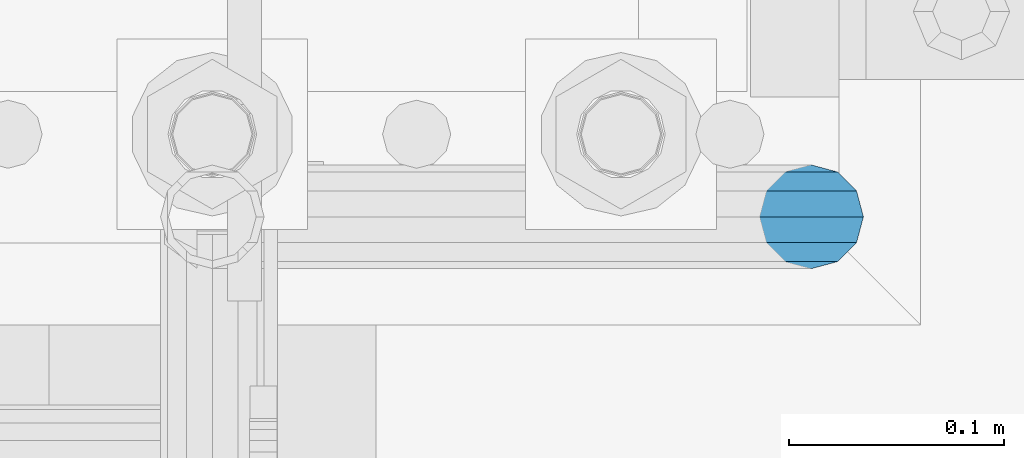
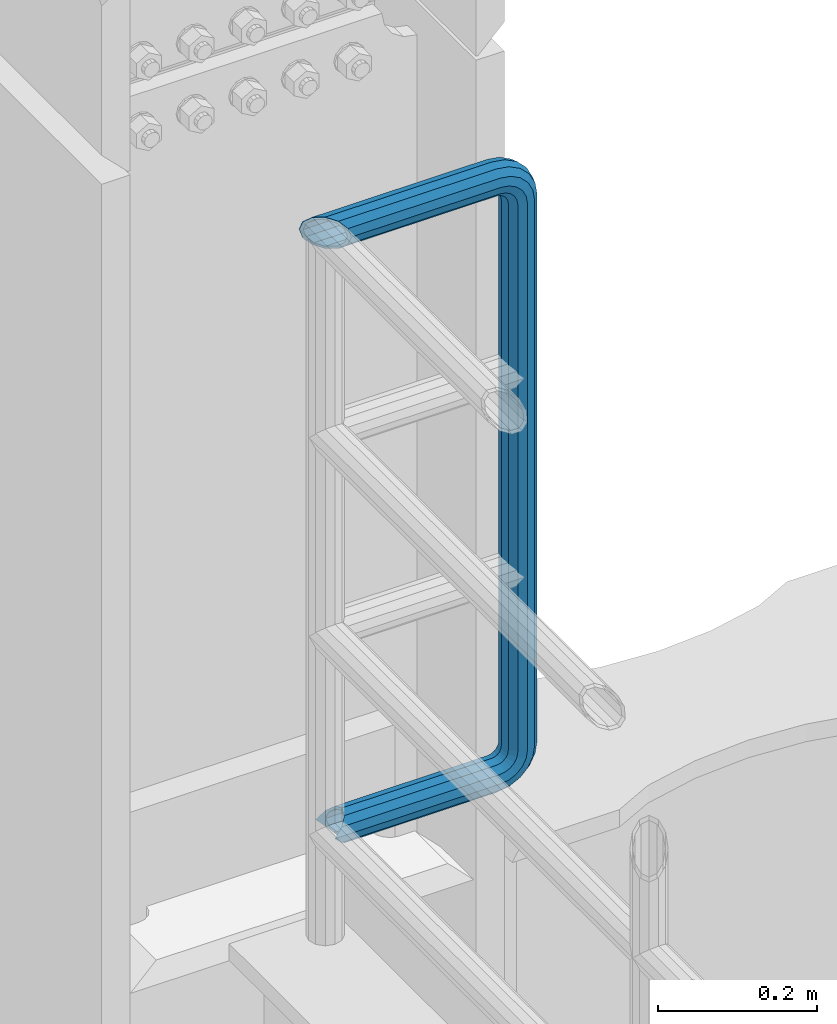
# One storey, part 1055 of 1876: 1 beam, 1 element without a shape of its own.
"""IFC2X3 building model written with IfcOpenShell, lengths in millimetres."""

from ifc_helpers import new_model, si_unit, frame, origin_with_axes, place, context, subcontext, project, spatial, faceted_brep, material, type_object, element, aggregate, save


model = new_model("IFC2X3")

# Units and contexts
model_context = context("Model", 3, precision=1e-05, world=origin_with_axes())
body_context = subcontext(model_context, "Body", "Model", "MODEL_VIEW")
ifc_project = project(units=[si_unit("LENGTHUNIT", "METRE", prefix="MILLI"), si_unit("AREAUNIT", "SQUARE_METRE"), si_unit("VOLUMEUNIT", "CUBIC_METRE"), si_unit("MASSUNIT", "GRAM", prefix="KILO"), si_unit("TIMEUNIT", "SECOND"), si_unit("PLANEANGLEUNIT", "RADIAN"), si_unit("SOLIDANGLEUNIT", "STERADIAN"), si_unit("THERMODYNAMICTEMPERATUREUNIT", "DEGREE_CELSIUS"), si_unit("LUMINOUSINTENSITYUNIT", "LUMEN")], contexts=[model_context])

# Site, building, storey
site_placement = place(None, origin_with_axes())
site = spatial("IfcSite", under=ifc_project, at=site_placement, CompositionType="ELEMENT")
building_placement = place(site_placement, origin_with_axes())
building = spatial("IfcBuilding", under=site, at=building_placement, Name="Undefined", CompositionType="ELEMENT")
storey_placement = place(building_placement, origin_with_axes())
storey = spatial("IfcBuildingStorey", under=building, at=storey_placement, Name="Undefined", CompositionType="ELEMENT", Elevation=0.0)

# Assembly, beam
assembly_placement = place(storey_placement, origin_with_axes())
assembly = element("IfcElementAssembly", 1, at=assembly_placement, inside=storey, Name="RAIL", AssemblyPlace="NOTDEFINED", PredefinedType="RIGID_FRAME")
ifc_material = material()
beam_type = type_object("IfcBeamType", Name="PIPE1-1/2SCH40", PredefinedType="NOTDEFINED")
beam_placement = place(assembly_placement, frame((-3.18323145620525e-12, 13499.7063, 14385.925), z_axis=(0.0, 0.0, 1.0), x_axis=(1.0, 0.0, 0.0)))
beam = element("IfcBeam", 2, at=beam_placement, type_object=beam_type, material=ifc_material, Name="RAIL", ObjectType="PIPE1-1/2SCH40", context=body_context, shape_type="Brep", body=[
    faceted_brep([(1.20714750983051e-12, 24.1299999999974, -914.399963378906), (12.0650000000014, 20.8971929933159, -926.464963378905), (12.0650000000014, 20.8971929933177, -902.334963378908), (12.0650000000014, -20.8971929933195, -902.334963378908), (12.0650000000014, -20.8971929933195, -926.464963378905), (1.52133659548828e-12, -24.130000000001, -914.399963378906), (20.8971929933199, -12.0650000000023, -893.502770385589), (20.8971929933199, -12.0650000000005, -898.533841947723), (15.2545715621378, -17.7076214311819, -904.176463378906), (12.5151929933181, -20.4470000000019, -914.399963378906), (15.2545715621376, -17.7076214311819, -924.623463378906), (20.8971929933199, -12.0650000000005, -930.26608481009), (20.8971929933199, -12.0650000000023, -935.297156372224), (24.1300000000014, -1.81898940354586e-12, -934.846963378906), (24.1300000000014, -1.81898940354586e-12, -938.529963378907), (21.3906214311813, -10.2235000000019, -932.107584810088), (21.3906214311823, 10.2234999999982, -932.107584810088), (20.8971929933199, 12.0650000000005, -930.266084810086), (20.8971929933199, 12.0649999999987, -935.297156372224), (15.2545715621413, 17.7076214311783, -924.623463378906), (12.5151929933216, 20.4469999999983, -914.399963378906), (15.2545715621411, 17.7076214311783, -904.176463378906), (20.8971929933199, 12.0650000000005, -898.533841947727), (20.8971929933199, 12.0649999999987, -893.502770385589), (21.3906214311822, 10.2234999999982, -896.692341947724), (24.1300000000014, 0.0, -893.952963378906), (24.1300000000014, 0.0, -890.269963378905), (21.3906214311814, -10.2235000000019, -896.692341947724), (241.299995422363, -20.8971929933177, 12.0649999999987), (241.299995422363, -24.1299999999992, 0.0), (253.073542436527, -24.1299999999992, -1.86474665447167), (256.801832473661, -20.8971929933177, 9.60975021462946), (241.299995422363, -12.0650000000005, 20.8971929933177), (259.531130206197, -12.0650000000005, 18.0096649141014), (241.299995422363, 0.0, 24.130000000001), (260.530122510796, 0.0, 21.084247083727), (241.299995422363, 12.0650000000005, 20.8971929933177), (259.531130206197, 12.0650000000005, 18.0096649141014), (241.299995422363, 20.8971929933177, 12.0649999999987), (256.801832473661, 20.8971929933177, 9.60975021462946), (241.299995422363, 24.1299999999992, 0.0), (253.073542436527, 24.1299999999992, -1.86474665447167), (241.299995422363, 20.8971929933177, -12.0649999999987), (249.345252399393, 20.8971929933177, -13.3392435235728), (241.299995422363, 12.0650000000005, -20.8971929933177), (246.615954666858, 12.0650000000005, -21.7391582230448), (241.299995422363, 0.0, -24.130000000001), (245.616962362259, 0.0, -24.8137403926739), (241.299995422363, -12.0650000000005, -20.8971929933177), (246.615954666858, -12.0650000000005, -21.7391582230448), (241.299995422363, -20.8971929933177, -12.0649999999987), (249.345252399393, -20.8971929933177, -13.3392435235728), (267.334993896485, 20.8971929933177, -38.0999984741211), (279.399993896485, 24.1299999999992, -38.0999984741211), (279.399993896484, 24.1299999999992, -876.299964904785), (267.334993896484, 20.8971929933177, -876.299964904785), (291.464993896486, 20.8971929933177, -38.0999984741211), (291.464993896484, 20.8971929933177, -876.299964904785), (300.297186889804, 12.0650000000005, -38.0999984741211), (300.297186889803, 12.0650000000005, -876.299964904785), (303.529993896486, 0.0, -38.0999984741211), (303.529993896484, 0.0, -876.299964904785), (300.297186889804, -12.0650000000005, -38.0999984741211), (300.297186889803, -12.0650000000005, -876.299964904785), (291.464993896486, -20.8971929933177, -38.0999984741211), (291.464993896484, -20.8971929933177, -876.299964904785), (279.399993896484, -24.1299999999992, -38.0999984741211), (279.399993896484, -24.1299999999992, -876.299964904785), (267.334993896485, -20.8971929933177, -38.0999984741211), (267.334993896484, -20.8971929933177, -876.299964904785), (258.502800903167, -12.0650000000005, -38.0999984741211), (258.502800903166, -12.0650000000005, -876.299964904785), (255.269993896485, 0.0, -38.0999984741211), (255.269993896484, 0.0, -876.299964904785), (258.502800903167, 12.0650000000005, -38.0999984741211), (258.502800903166, 12.0650000000005, -876.299964904785), (257.660835673438, 12.0650000000005, -881.615924149282), (254.586253503809, 0.0, -880.616931844681), (257.660835673438, -12.0650000000005, -881.615924149282), (266.06075037291, -20.8971929933177, -884.345221881817), (277.535247242011, -24.130000000001, -888.073511918952), (289.009744111112, -20.8971929933195, -891.801801956084), (297.409658810584, -12.0650000000005, -894.531099688622), (300.484240980214, 0.0, -895.53009199322), (297.409658810584, 12.0650000000005, -894.531099688622), (289.009744111112, 20.8971929933177, -891.801801956084), (277.535247242011, 24.1299999999992, -888.073511918952), (266.06075037291, 20.8971929933177, -884.345221881817), (241.299995422364, -1.81898940354586e-12, -938.529963378911), (241.299995422364, -12.0650000000005, -935.297156372228), (241.299995422364, -20.8971929933195, -926.464963378909), (241.299995422363, -24.130000000001, -914.399963378906), (241.299995422363, -20.8971929933195, -902.334963378908), (241.299995422363, -12.0650000000005, -893.502770385589), (241.299995422363, 0.0, -890.269963378909), (241.299995422364, 20.8971929933177, -926.464963378909), (241.299995422364, 12.0649999999987, -935.297156372228), (241.299995422364, 24.1299999999992, -914.39996337891), (241.299995422363, 20.8971929933177, -902.334963378908), (241.299995422363, 12.0649999999987, -893.502770385589), (260.530122510801, 0.0, -935.484210462637), (259.531130206202, 12.0649999999987, -932.409628293008), (259.531130206201, -12.0650000000005, -932.409628293008), (256.801832473666, -20.8971929933195, -924.009713593536), (253.07354243653, -24.130000000001, -912.535216724435), (249.345252399395, -20.8971929933195, -901.060719855333), (246.615954666859, -12.0650000000005, -892.660805155861), (245.61696236226, 0.0, -889.586222986232), (246.615954666859, 12.0649999999987, -892.660805155861), (249.345252399395, 20.8971929933177, -901.060719855333), (253.07354243653, 24.1299999999992, -912.535216724435), (256.801832473666, 20.8971929933177, -924.009713593536), (275.977674493594, 12.0649999999987, -924.029695422345), (270.786241706733, 20.8971929933177, -916.884301193139), (277.877870775644, 0.0, -926.645091230272), (275.977674493608, -12.0650000000005, -924.029695422334), (270.786241706733, -20.8971929933195, -916.884301193139), (263.694612637823, -24.130000000001, -907.123511156005), (256.602983568912, -20.8971929933195, -897.362721118872), (251.411550782037, -12.0650000000005, -890.21732688968), (249.511354500001, 0.0, -887.601931081743), (251.411550782037, 12.0650000000005, -890.21732688968), (256.602983568912, 20.8971929933177, -897.362721118872), (263.694612637823, 24.1299999999992, -907.123511156005), (281.884331710718, 20.8971929933177, -905.786211189152), (272.123541673585, 24.1299999999992, -898.694582120243), (289.029725939912, 12.0650000000005, -910.977643976028), (291.645121747852, 0.0, -912.877840258065), (289.029725939912, -12.0650000000005, -910.977643976028), (281.884331710718, -20.8971929933195, -905.786211189152), (272.123541673585, -24.130000000001, -898.694582120243), (262.362751636451, -20.8971929933195, -891.602953051333), (255.217357407258, -12.0650000000005, -886.411520264461), (252.601961599318, 0.0, -884.511323982424), (255.217357407258, 12.0650000000005, -886.411520264461), (262.362751636451, 20.8971929933177, -891.602953051333), (266.060750372911, 20.8971929933177, -30.0547414970897), (257.660835673439, 12.0650000000005, -32.7840392296275), (277.535247242011, 24.1299999999992, -26.3264514599541), (289.009744111112, 20.8971929933177, -22.5981614228222), (297.409658810584, 12.0650000000005, -19.8688636902843), (300.484240980213, 0.0, -18.8698713856866), (297.409658810584, -12.0650000000005, -19.8688636902843), (289.009744111112, -20.8971929933177, -22.5981614228222), (277.535247242011, -24.1299999999992, -26.3264514599541), (266.060750372911, -20.8971929933177, -30.0547414970897), (257.660835673439, -12.0650000000005, -32.7840392296275), (254.58625350381, 0.0, -33.7830315342253), (255.217357407257, 12.0650000000005, -27.9884431144455), (252.601961599318, 0.0, -29.8886393964822), (262.362751636451, 20.8971929933177, -22.7970103275729), (272.123541673583, 24.1299999999992, -15.7053812586601), (281.884331710716, 20.8971929933177, -8.61375218975081), (289.029725939909, 12.0650000000005, -3.42231940287456), (291.645121747848, 0.0, -1.52212312084157), (289.029725939909, -12.0650000000005, -3.42231940287456), (281.884331710716, -20.8971929933177, -8.61375218975081), (272.123541673583, -24.1299999999992, -15.7053812586601), (262.362751636451, -20.8971929933177, -22.7970103275729), (255.217357407257, -12.0650000000005, -27.9884431144455), (249.511354500002, 0.0, -26.7980322971671), (251.411550782037, -12.0650000000005, -24.1826364892258), (251.411550782037, 12.0650000000005, -24.1826364892258), (256.602983568912, 20.8971929933177, -17.037242260034), (263.694612637822, 24.1299999999992, -7.27645222290084), (270.786241706732, 20.8971929933177, 2.48433781423228), (275.977674493607, 12.0650000000005, 9.62973204342416), (277.877870775642, 0.0, 12.2451278513654), (275.977674493607, -12.0650000000005, 9.62973204342416), (270.786241706732, -20.8971929933177, 2.48433781423228), (263.694612637822, -24.1299999999992, -7.27645222290084), (256.602983568912, -20.8971929933177, -17.037242260034), (24.1299999999854, -24.1299999999992, 0.0), (20.8971929933039, -20.8971929933177, -12.0649999999987), (12.0649999999854, -12.0650000000005, -20.8971929933177), (20.8971929933249, -12.0650000000005, -20.8971929933177), (16.4810997545745, -16.4810997545883, -16.48109323873), (24.1300000000063, 0.0, -24.130000000001), (-1.45519152283669e-11, 0.0, -24.130000000001), (20.8971929933249, 12.0650000000005, -20.8971929933177), (-12.0650000000145, 12.0650000000005, -20.8971929933177), (-20.897192993333, 20.8971929933177, -12.0649999999987), (-12.0649999999986, 20.8971929933177, -12.0649999999987), (12.0650000000064, 20.8971929933177, -12.0649999999987), (-16.481093238746, 16.4810932387318, -16.4810997545865), (0.0, 24.1299999999992, 0.0), (-24.1300000000145, 24.1299999999992, 0.0), (-20.897192993333, 20.8971929933177, 12.0649999999987), (-12.0650000000145, 12.0650000000005, 20.8971929933177), (-1.45519152283669e-11, 0.0, 24.130000000001), (12.0649999999854, -12.0650000000005, 20.8971929933177), (20.8971929933039, -20.8971929933177, 12.0649999999987), (241.299995422363, -17.7076214311801, 10.2235000000001), (241.299995422363, -20.4470000000001, 0.0), (20.4469999999854, -20.4470000000001, 0.0), (17.7076214311658, -17.7076214311801, 10.2235000000001), (241.299995422363, 0.0, 20.4470000000001), (241.299995422363, -10.2235000000001, 17.7076214311819), (10.2234999999854, -10.2235000000001, 17.7076214311819), (-1.45519152283669e-11, 0.0, 20.4470000000001), (241.299995422363, 10.2235000000001, 17.7076214311819), (-10.2235000000145, 10.2235000000001, 17.7076214311819), (241.299995422363, 17.7076214311801, 10.2235000000001), (-17.7076214311949, 17.7076214311801, 10.2235000000001), (241.299995422363, 20.4470000000001, 0.0), (-20.4470000000145, 20.4470000000001, 0.0), (241.299995422363, 17.7076214311801, -10.2235000000001), (-17.7076214311949, 17.7076214311801, -10.2235000000001), (241.299995422363, 10.2235000000001, -17.7076214311819), (-10.2235000000145, 10.2235000000001, -17.7076214311819), (241.299995422363, 0.0, -20.4470000000001), (-1.45519152283669e-11, 0.0, -20.4470000000001), (241.299995422363, -10.2235000000001, -17.7076214311819), (10.2234999999854, -10.2235000000001, -17.7076214311819), (241.299995422363, -17.7076214311801, -10.2235000000001), (17.7076214311658, -17.7076214311801, -10.2235000000001), (258.545498388721, -10.2235000000001, 14.9762020957387), (256.23277767852, -17.7076214311801, 7.85837963987069), (253.073542436527, -20.4470000000001, -1.86474665447167), (249.914307194535, -17.7076214311801, -11.5878729488177), (247.601586484334, -10.2235000000001, -18.7056954046857), (246.755071952542, 0.0, -21.31099924316), (247.601586484334, 10.2235000000001, -18.7056954046857), (249.914307194535, 17.7076214311801, -11.5878729488177), (253.073542436527, 20.4470000000001, -1.86474665447167), (256.23277767852, 17.7076214311801, 7.85837963987069), (258.545498388721, 10.2235000000001, 14.9762020957387), (259.392012920513, 0.0, 17.5815059342131), (275.713057691449, 0.0, 9.26551826108334), (274.10289136825, -10.2235000000001, 7.04931444488102), (274.10289136825, 10.2235000000001, 7.04931444488102), (269.703835164635, 17.7076214311801, 0.994533019089431), (263.694612637822, 20.4470000000001, -7.27645222290084), (257.685390111009, 17.7076214311801, -15.5474374648911), (253.286333907394, 10.2235000000001, -21.6022188906827), (251.676167584195, 0.0, -23.818422706885), (253.286333907394, -10.2235000000001, -21.6022188906827), (257.685390111009, -17.7076214311801, -15.5474374648911), (263.694612637822, -20.4470000000001, -7.27645222290084), (269.703835164635, -17.7076214311801, 0.994533019089431), (286.449308341364, -10.2235000000001, -5.29710252823133), (280.394526915574, -17.7076214311801, -9.69615873184739), (288.665512157566, 0.0, -3.68693620503473), (286.449308341364, 10.2235000000001, -5.29710252823133), (280.394526915574, 17.7076214311801, -9.69615873184739), (272.123541673583, 20.4470000000001, -15.7053812586601), (263.852556431592, 17.7076214311801, -21.7146037854764), (257.797775005802, 10.2235000000001, -26.1136599890888), (255.581571189601, 0.0, -27.723826312289), (257.797775005802, -10.2235000000001, -26.1136599890888), (263.852556431592, -17.7076214311801, -21.7146037854764), (272.123541673583, -20.4470000000001, -15.7053812586601), (287.258373536355, -17.7076214311801, -23.1672162179639), (277.535247242011, -20.4470000000001, -26.3264514599541), (294.376195992223, -10.2235000000001, -20.8544955077632), (296.981499830698, 0.0, -20.00798097597), (294.376195992223, 10.2235000000001, -20.8544955077632), (287.258373536355, 17.7076214311801, -23.1672162179639), (277.535247242011, 20.4470000000001, -26.3264514599541), (267.812120947668, 17.7076214311801, -29.485686701948), (260.6942984918, 10.2235000000001, -31.7984074121487), (258.088994653325, 0.0, -32.6449219439419), (260.6942984918, -10.2235000000001, -31.7984074121487), (267.812120947668, -17.7076214311801, -29.485686701948), (279.399993896484, -20.4470000000001, -38.0999984741211), (269.176493896485, -17.7076214311801, -38.0999984741211), (289.623493896486, -17.7076214311801, -38.0999984741211), (297.107615327666, -10.2235000000001, -38.0999984741211), (299.846993896486, 0.0, -38.0999984741211), (297.107615327666, 10.2235000000001, -38.0999984741211), (289.623493896486, 17.7076214311801, -38.0999984741211), (279.399993896485, 20.4470000000001, -38.0999984741211), (269.176493896485, 17.7076214311801, -38.0999984741211), (261.692372465305, 10.2235000000001, -38.0999984741211), (258.952993896485, 0.0, -38.0999984741211), (261.692372465305, -10.2235000000001, -38.0999984741211), (269.176493896484, -17.7076214311801, -876.299964904785), (261.692372465304, -10.2235000000001, -876.299964904785), (258.952993896484, 0.0, -876.299964904785), (261.692372465304, 10.2235000000001, -876.299964904785), (269.176493896484, 17.7076214311801, -876.299964904785), (279.399993896484, 20.4470000000001, -876.299964904785), (289.623493896484, 17.7076214311801, -876.299964904785), (297.107615327665, 10.2235000000001, -876.299964904785), (299.846993896484, 0.0, -876.299964904785), (297.107615327665, -10.2235000000001, -876.299964904785), (289.623493896484, -17.7076214311801, -876.299964904785), (279.399993896484, -20.4470000000001, -876.299964904785), (277.535247242011, -20.4470000000001, -888.073511918952), (267.812120947667, -17.7076214311801, -884.914276676958), (260.694298491799, -10.2235000000001, -882.601555966758), (258.088994653324, 0.0, -881.755041434964), (260.694298491799, 10.2235000000001, -882.601555966758), (267.812120947668, 17.7076214311801, -884.914276676958), (277.535247242011, 20.4470000000001, -888.073511918952), (287.258373536355, 17.7076214311801, -891.232747160942), (294.376195992223, 10.2235000000001, -893.545467871143), (296.981499830699, 0.0, -894.391982402936), (294.376195992223, -10.2235000000001, -893.545467871143), (287.258373536355, -17.7076214311801, -891.232747160942), (280.394526915577, -17.7076214311801, -904.703804647055), (272.123541673585, -20.4470000000001, -898.694582120243), (286.449308341367, -10.2235000000001, -909.102860850671), (288.665512157569, 0.0, -910.713027173868), (286.449308341367, 10.2235000000001, -909.102860850671), (280.394526915577, 17.7076214311801, -904.703804647055), (272.123541673585, 20.4470000000001, -898.694582120243), (263.852556431593, 17.7076214311801, -892.68535959343), (257.797775005802, 10.2235000000001, -888.286303389817), (255.581571189601, 0.0, -886.676137066617), (257.797775005802, -10.2235000000001, -888.286303389817), (263.852556431593, -17.7076214311801, -892.68535959343), (263.694612637823, -20.4470000000001, -907.123511156005), (257.685390111009, -17.7076214311801, -898.852525914015), (269.703835164636, -17.7076214311801, -915.394496397999), (274.102891368238, -10.2235000000001, -921.449277823798), (275.71305769145, 0.0, -923.66548163999), (274.102891368251, 10.2235000000001, -921.449277823787), (269.703835164636, 17.7076214311801, -915.394496397999), (263.694612637823, 20.4470000000001, -907.123511156005), (257.685390111009, 17.7076214311801, -898.852525914015), (253.286333907394, 10.2235000000001, -892.797744488227), (251.676167584195, 0.0, -890.581540672025), (253.286333907394, -10.2235000000001, -892.797744488227), (249.914307194537, -17.7076214311801, -902.812090430092), (247.601586484335, -10.2235000000001, -895.694267974224), (253.07354243653, -20.4470000000001, -912.535216724435), (256.232777678524, -17.7076214311819, -922.258343018777), (258.545498388725, -10.2235000000001, -929.376165474645), (259.392012920517, 0.0, -931.981469313119), (258.545498388725, 10.2235000000001, -929.376165474645), (256.232777678524, 17.7076214311801, -922.258343018777), (253.07354243653, 20.4470000000001, -912.535216724435), (249.914307194537, 17.7076214311801, -902.812090430092), (247.601586484335, 10.2235000000001, -895.694267974224), (246.755071952543, 0.0, -893.088964135746), (241.299995422363, -10.2235000000001, -896.692341947728), (241.299995422363, 0.0, -893.95296337891), (241.299995422363, -17.7076214311819, -904.17646337891), (241.299995422363, -20.4470000000001, -914.399963378906), (241.299995422364, -17.7076214311819, -924.62346337891), (241.299995422364, -10.2235000000001, -932.107584810088), (241.299995422364, -1.81898940354586e-12, -934.84696337891), (241.299995422364, 10.2234999999982, -932.107584810088), (241.299995422364, 17.7076214311801, -924.62346337891), (241.299995422364, 20.4470000000001, -914.39996337891), (241.299995422363, 17.7076214311801, -904.17646337891), (241.299995422363, 10.2235000000001, -896.692341947728)], [[[0, 1, 2]], [[3, 4, 5]], [[6, 7, 8, 9, 10, 11, 12, 4, 3]], [[13, 14, 12, 11, 15]], [[16, 17, 18, 14, 13]], [[2, 1, 18, 17, 19, 20, 21, 22, 23]], [[23, 22, 24, 25, 26]], [[26, 25, 27, 7, 6]], [[28, 29, 30, 31]], [[32, 28, 31, 33]], [[34, 32, 33, 35]], [[36, 34, 35, 37]], [[38, 36, 37, 39]], [[40, 38, 39, 41]], [[42, 40, 41, 43]], [[44, 42, 43, 45]], [[46, 44, 45, 47]], [[48, 46, 47, 49]], [[50, 48, 49, 51]], [[52, 53, 54, 55]], [[53, 56, 57, 54]], [[56, 58, 59, 57]], [[58, 60, 61, 59]], [[60, 62, 63, 61]], [[62, 64, 65, 63]], [[64, 66, 67, 65]], [[66, 68, 69, 67]], [[68, 70, 71, 69]], [[70, 72, 73, 71]], [[72, 74, 75, 73]], [[73, 75, 76, 77]], [[71, 73, 77, 78]], [[69, 71, 78, 79]], [[67, 69, 79, 80]], [[65, 67, 80, 81]], [[63, 65, 81, 82]], [[61, 63, 82, 83]], [[59, 61, 83, 84]], [[57, 59, 84, 85]], [[54, 57, 85, 86]], [[55, 54, 86, 87]], [[88, 89, 12, 14]], [[89, 90, 4, 12]], [[90, 91, 5, 4]], [[91, 92, 3, 5]], [[92, 93, 6, 3]], [[93, 94, 26, 6]], [[95, 96, 18, 1]], [[97, 95, 1, 0]], [[98, 97, 0, 2]], [[99, 98, 2, 23]], [[94, 99, 23, 26]], [[96, 88, 14, 18]], [[100, 88, 96, 101]], [[102, 89, 88, 100]], [[103, 90, 89, 102]], [[104, 91, 90, 103]], [[105, 92, 91, 104]], [[106, 93, 92, 105]], [[107, 94, 93, 106]], [[108, 99, 94, 107]], [[109, 98, 99, 108]], [[110, 97, 98, 109]], [[111, 95, 97, 110]], [[101, 96, 95, 111]], [[112, 101, 111, 113]], [[114, 100, 101, 112]], [[115, 102, 100, 114]], [[116, 103, 102, 115]], [[117, 104, 103, 116]], [[118, 105, 104, 117]], [[119, 106, 105, 118]], [[120, 107, 106, 119]], [[121, 108, 107, 120]], [[122, 109, 108, 121]], [[123, 110, 109, 122]], [[113, 111, 110, 123]], [[124, 113, 123, 125]], [[126, 112, 113, 124]], [[127, 114, 112, 126]], [[128, 115, 114, 127]], [[129, 116, 115, 128]], [[130, 117, 116, 129]], [[131, 118, 117, 130]], [[132, 119, 118, 131]], [[133, 120, 119, 132]], [[134, 121, 120, 133]], [[135, 122, 121, 134]], [[125, 123, 122, 135]], [[86, 125, 135, 87]], [[85, 124, 125, 86]], [[84, 126, 124, 85]], [[83, 127, 126, 84]], [[82, 128, 127, 83]], [[81, 129, 128, 82]], [[80, 130, 129, 81]], [[79, 131, 130, 80]], [[78, 132, 131, 79]], [[77, 133, 132, 78]], [[76, 134, 133, 77]], [[87, 135, 134, 76]], [[75, 55, 87, 76]], [[74, 52, 55, 75]], [[136, 52, 74, 137]], [[138, 53, 52, 136]], [[139, 56, 53, 138]], [[140, 58, 56, 139]], [[141, 60, 58, 140]], [[142, 62, 60, 141]], [[143, 64, 62, 142]], [[144, 66, 64, 143]], [[145, 68, 66, 144]], [[146, 70, 68, 145]], [[147, 72, 70, 146]], [[137, 74, 72, 147]], [[148, 137, 147, 149]], [[150, 136, 137, 148]], [[151, 138, 136, 150]], [[152, 139, 138, 151]], [[153, 140, 139, 152]], [[154, 141, 140, 153]], [[155, 142, 141, 154]], [[156, 143, 142, 155]], [[157, 144, 143, 156]], [[158, 145, 144, 157]], [[159, 146, 145, 158]], [[149, 147, 146, 159]], [[160, 149, 159, 161]], [[162, 148, 149, 160]], [[163, 150, 148, 162]], [[164, 151, 150, 163]], [[165, 152, 151, 164]], [[166, 153, 152, 165]], [[167, 154, 153, 166]], [[168, 155, 154, 167]], [[169, 156, 155, 168]], [[170, 157, 156, 169]], [[171, 158, 157, 170]], [[161, 159, 158, 171]], [[49, 161, 171, 51]], [[47, 160, 161, 49]], [[45, 162, 160, 47]], [[43, 163, 162, 45]], [[41, 164, 163, 43]], [[39, 165, 164, 41]], [[37, 166, 165, 39]], [[35, 167, 166, 37]], [[33, 168, 167, 35]], [[31, 169, 168, 33]], [[30, 170, 169, 31]], [[51, 171, 170, 30]], [[29, 50, 51, 30]], [[50, 29, 172, 173]], [[174, 175, 48, 50, 173, 176]], [[177, 46, 48, 175, 174, 178]], [[179, 44, 46, 177, 178, 180]], [[181, 182, 183, 42, 44, 179, 180, 184]], [[185, 40, 42, 183, 182, 181, 186]], [[38, 40, 185, 186, 187]], [[36, 38, 187, 188]], [[34, 36, 188, 189]], [[32, 34, 189, 190]], [[28, 32, 190, 191]], [[29, 28, 191, 172]], [[192, 193, 194, 195]], [[196, 197, 198, 199]], [[200, 196, 199, 201]], [[202, 200, 201, 203]], [[204, 202, 203, 205]], [[206, 204, 205, 207]], [[208, 206, 207, 209]], [[210, 208, 209, 211]], [[212, 210, 211, 213]], [[214, 212, 213, 215]], [[193, 214, 215, 194]], [[190, 189, 188, 187, 186, 181, 184, 180, 178, 174, 176, 173, 172, 191], [213, 211, 209, 207, 205, 203, 201, 199, 198, 195, 194, 215]], [[197, 192, 195, 198]], [[192, 197, 216, 217]], [[193, 192, 217, 218]], [[214, 193, 218, 219]], [[212, 214, 219, 220]], [[210, 212, 220, 221]], [[208, 210, 221, 222]], [[206, 208, 222, 223]], [[204, 206, 223, 224]], [[202, 204, 224, 225]], [[200, 202, 225, 226]], [[196, 200, 226, 227]], [[197, 196, 227, 216]], [[227, 228, 229, 216]], [[226, 230, 228, 227]], [[225, 231, 230, 226]], [[224, 232, 231, 225]], [[223, 233, 232, 224]], [[222, 234, 233, 223]], [[221, 235, 234, 222]], [[220, 236, 235, 221]], [[219, 237, 236, 220]], [[218, 238, 237, 219]], [[217, 239, 238, 218]], [[216, 229, 239, 217]], [[229, 240, 241, 239]], [[228, 242, 240, 229]], [[230, 243, 242, 228]], [[231, 244, 243, 230]], [[232, 245, 244, 231]], [[233, 246, 245, 232]], [[234, 247, 246, 233]], [[235, 248, 247, 234]], [[236, 249, 248, 235]], [[237, 250, 249, 236]], [[238, 251, 250, 237]], [[239, 241, 251, 238]], [[241, 252, 253, 251]], [[240, 254, 252, 241]], [[242, 255, 254, 240]], [[243, 256, 255, 242]], [[244, 257, 256, 243]], [[245, 258, 257, 244]], [[246, 259, 258, 245]], [[247, 260, 259, 246]], [[248, 261, 260, 247]], [[249, 262, 261, 248]], [[250, 263, 262, 249]], [[251, 253, 263, 250]], [[253, 264, 265, 263]], [[252, 266, 264, 253]], [[254, 267, 266, 252]], [[255, 268, 267, 254]], [[256, 269, 268, 255]], [[257, 270, 269, 256]], [[258, 271, 270, 257]], [[259, 272, 271, 258]], [[260, 273, 272, 259]], [[261, 274, 273, 260]], [[262, 275, 274, 261]], [[263, 265, 275, 262]], [[275, 265, 276, 277]], [[274, 275, 277, 278]], [[273, 274, 278, 279]], [[272, 273, 279, 280]], [[271, 272, 280, 281]], [[270, 271, 281, 282]], [[269, 270, 282, 283]], [[268, 269, 283, 284]], [[267, 268, 284, 285]], [[266, 267, 285, 286]], [[264, 266, 286, 287]], [[265, 264, 287, 276]], [[276, 287, 288, 289]], [[277, 276, 289, 290]], [[278, 277, 290, 291]], [[279, 278, 291, 292]], [[280, 279, 292, 293]], [[281, 280, 293, 294]], [[282, 281, 294, 295]], [[283, 282, 295, 296]], [[284, 283, 296, 297]], [[285, 284, 297, 298]], [[286, 285, 298, 299]], [[287, 286, 299, 288]], [[299, 300, 301, 288]], [[298, 302, 300, 299]], [[297, 303, 302, 298]], [[296, 304, 303, 297]], [[295, 305, 304, 296]], [[294, 306, 305, 295]], [[293, 307, 306, 294]], [[292, 308, 307, 293]], [[291, 309, 308, 292]], [[290, 310, 309, 291]], [[289, 311, 310, 290]], [[288, 301, 311, 289]], [[301, 312, 313, 311]], [[300, 314, 312, 301]], [[302, 315, 314, 300]], [[303, 316, 315, 302]], [[304, 317, 316, 303]], [[305, 318, 317, 304]], [[306, 319, 318, 305]], [[307, 320, 319, 306]], [[308, 321, 320, 307]], [[309, 322, 321, 308]], [[310, 323, 322, 309]], [[311, 313, 323, 310]], [[313, 324, 325, 323]], [[312, 326, 324, 313]], [[314, 327, 326, 312]], [[315, 328, 327, 314]], [[316, 329, 328, 315]], [[317, 330, 329, 316]], [[318, 331, 330, 317]], [[319, 332, 331, 318]], [[320, 333, 332, 319]], [[321, 334, 333, 320]], [[322, 335, 334, 321]], [[323, 325, 335, 322]], [[325, 336, 337, 335]], [[324, 338, 336, 325]], [[326, 339, 338, 324]], [[327, 340, 339, 326]], [[328, 341, 340, 327]], [[329, 342, 341, 328]], [[330, 343, 342, 329]], [[331, 344, 343, 330]], [[332, 345, 344, 331]], [[333, 346, 345, 332]], [[334, 347, 346, 333]], [[335, 337, 347, 334]], [[347, 337, 25, 24]], [[21, 346, 347, 24, 22]], [[345, 346, 21, 20]], [[344, 345, 20, 19]], [[343, 344, 19, 17, 16]], [[342, 343, 16, 13]], [[341, 342, 13, 15]], [[10, 340, 341, 15, 11]], [[339, 340, 10, 9]], [[338, 339, 9, 8]], [[336, 338, 8, 7, 27]], [[337, 336, 27, 25]]]),
])
aggregate(assembly, [beam])

save(model, "model.ifc")
